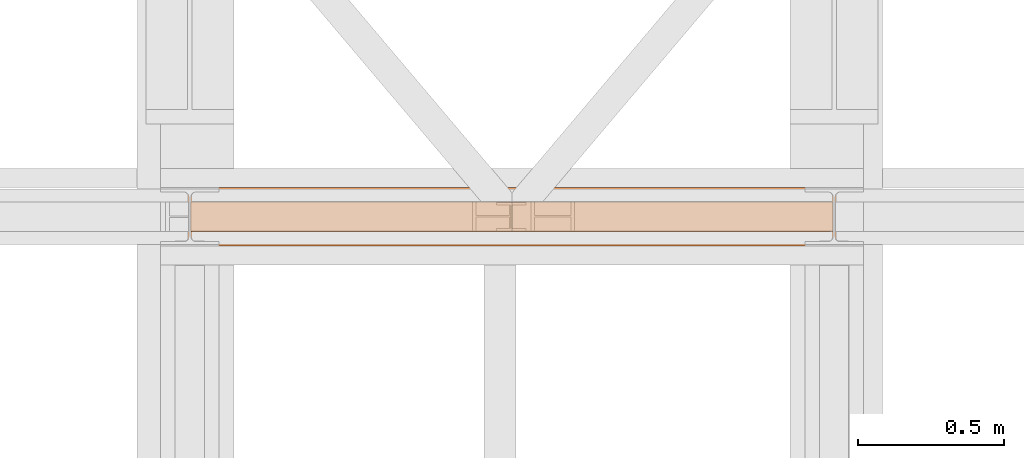
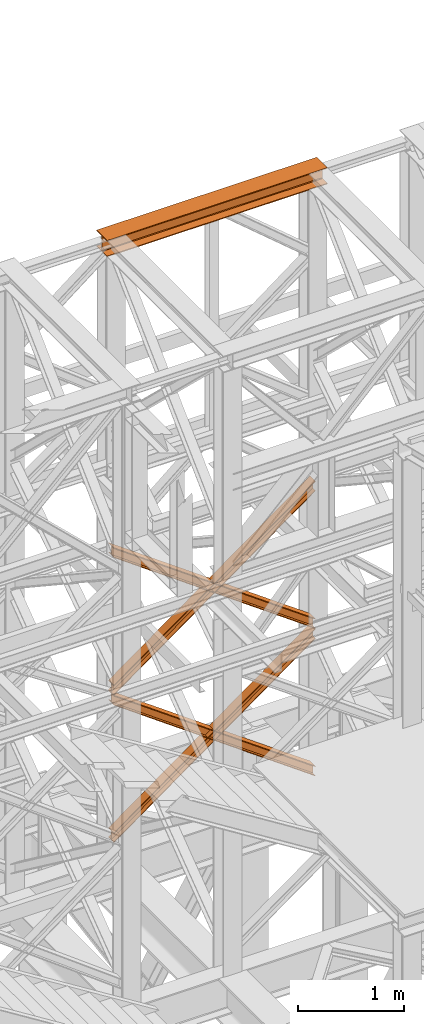
# One storey, part 119 of 208: 5 proxies.
"""IFC2X3 building model written with IfcOpenShell, lengths in millimetres."""

from ifc_helpers import new_model, entity, si_unit, converted_unit, frame, origin, origin_with_axes, place, context, subcontext, project, spatial, faceted_brep, element, save


model = new_model("IFC2X3")

# Units and contexts
model_context = context("Model", 3, precision=1e-05, world=origin())
plan_context = context("Plan", 3, precision=1e-05, world=origin())
body_context = subcontext(model_context, "Body", "Model", "MODEL_VIEW")
ifc_project = project(units=[si_unit("LENGTHUNIT", "METRE", prefix="MILLI"), converted_unit("PLANEANGLEUNIT", "DEGREE", entity("IfcPlaneAngleMeasure", 0.0174532925199433), si_unit("PLANEANGLEUNIT", "RADIAN"), dimensions=[0, 0, 0, 0, 0, 0, 0]), si_unit("AREAUNIT", "SQUARE_METRE"), si_unit("VOLUMEUNIT", "CUBIC_METRE")], contexts=[model_context, plan_context])

# Building, storey
building_placement = place(None, origin())
building = spatial("IfcBuilding", under=ifc_project, at=building_placement, CompositionType="COMPLEX")
storey_placement = place(building_placement, origin_with_axes())
storey = spatial("IfcBuildingStorey", under=building, at=storey_placement, Name="Geschoss", CompositionType="ELEMENT")

# Proxies
proxy_1_placement = place(storey_placement, frame((-106.745032961451, -13862.574391808, 12249.99005869381), z_axis=(0.0, 0.0, 1.0), x_axis=(1.0, 0.0, 0.0)))
element("IfcBuildingElementProxy", 1, at=proxy_1_placement, inside=storey, context=body_context, shape_type="Brep", body=[
    faceted_brep([(0.009999999999990905, 0.01000000000021828, 0.01000000000021828), (0.009999999999990905, 200.0100029802325, 0.01000000000021828), (0.009999999999990905, 200.0100029802325, 10.00999791383765), (0.009999999999990905, 121.2600035762789, 10.01000536441825), (0.009999999999990905, 111.9441915473344, 11.87455041170142), (0.009999999999990905, 105.1245498640838, 18.69419349193595), (0.009999999999990905, 103.2600015571716, 28.01000458955787), (0.009999999999990905, 103.2600015571716, 162.0100153779986), (0.009999999999990905, 105.1245498640838, 171.3258264756205), (0.009999999999990905, 111.9441915473344, 178.145469555855), (0.009999999999990905, 121.2600035762789, 180.0100146031382), (0.009999999999990905, 200.0100029802325, 180.0100146031382), (0.009999999999990905, 200.0100029802325, 190.0100125169756), (0.009999999999990905, 0.01000000000021828, 190.0100125169756), (0.009999999999990905, 0.01000000000021828, 180.0100146031382), (0.009999999999990905, 78.75999940395377, 180.0100146031382), (0.009999999999990905, 88.07581143289826, 178.145469555855), (0.009999999999990905, 94.89545311614893, 171.3258264756205), (0.009999999999990905, 96.76000142306111, 162.0100153779986), (0.009999999999990905, 96.76000142306111, 28.01000458955787), (0.009999999999990905, 94.89545311614893, 18.69419349193595), (0.009999999999990905, 88.07581143289826, 11.87455041170142), (0.009999999999990905, 78.75999940395377, 10.01000536441825), (0.009999999999990905, 0.01000000000021828, 10.00999791383765), (0.009999999999990905, 200.0100029802325, 0.01000000000021828), (0.009999999999990905, 0.01000000000021828, 0.01000000000021828), (2400.010002980233, 0.01000000000021828, 0.01000000000021828), (2400.010002980233, 200.0100029802325, 0.01000000000021828), (0.009999999999990905, 200.0100029802325, 10.00999791383765), (0.009999999999990905, 200.0100029802325, 0.01000000000021828), (2400.010002980233, 200.0100029802325, 0.01000000000021828), (2400.010002980233, 200.0100029802325, 10.00999791383765), (0.009999999999990905, 121.2600035762789, 10.01000536441825), (0.009999999999990905, 200.0100029802325, 10.00999791383765), (2400.010002980233, 200.0100029802325, 10.00999791383765), (2400.010002980233, 121.2600035762789, 10.01000536441825), (0.009999999999990905, 111.9441915473344, 11.87455041170142), (0.009999999999990905, 121.2600035762789, 10.01000536441825), (2400.010002980233, 121.2600035762789, 10.01000536441825), (2400.010002980233, 111.9441915473344, 11.87455041170142), (0.009999999999990905, 105.1245498640838, 18.69419349193595), (0.009999999999990905, 111.9441915473344, 11.87455041170142), (2400.010002980233, 111.9441915473344, 11.87455041170142), (2400.010002980233, 105.1245498640838, 18.69419349193595), (0.009999999999990905, 103.2600015571716, 28.01000458955787), (0.009999999999990905, 105.1245498640838, 18.69419349193595), (2400.010002980233, 105.1245498640838, 18.69419349193595), (2400.010002980233, 103.2600015571716, 28.01000458955787), (0.009999999999990905, 103.2600015571716, 162.0100153779986), (0.009999999999990905, 103.2600015571716, 28.01000458955787), (2400.010002980233, 103.2600015571716, 28.01000458955787), (2400.010002980233, 103.2600015571716, 162.0100153779986), (0.009999999999990905, 105.1245498640838, 171.3258264756205), (0.009999999999990905, 103.2600015571716, 162.0100153779986), (2400.010002980233, 103.2600015571716, 162.0100153779986), (2400.010002980233, 105.1245498640838, 171.3258264756205), (0.009999999999990905, 111.9441915473344, 178.145469555855), (0.009999999999990905, 105.1245498640838, 171.3258264756205), (2400.010002980233, 105.1245498640838, 171.3258264756205), (2400.010002980233, 111.9441915473344, 178.145469555855), (0.009999999999990905, 121.2600035762789, 180.0100146031382), (0.009999999999990905, 111.9441915473344, 178.145469555855), (2400.010002980233, 111.9441915473344, 178.145469555855), (2400.010002980233, 121.2600035762789, 180.0100146031382), (0.009999999999990905, 200.0100029802325, 180.0100146031382), (0.009999999999990905, 121.2600035762789, 180.0100146031382), (2400.010002980233, 121.2600035762789, 180.0100146031382), (2400.010002980233, 200.0100029802325, 180.0100146031382), (0.009999999999990905, 200.0100029802325, 190.0100125169756), (0.009999999999990905, 200.0100029802325, 180.0100146031382), (2400.010002980233, 200.0100029802325, 180.0100146031382), (2400.010002980233, 200.0100029802325, 190.0100125169756), (0.009999999999990905, 0.01000000000021828, 190.0100125169756), (0.009999999999990905, 200.0100029802325, 190.0100125169756), (2400.010002980233, 200.0100029802325, 190.0100125169756), (2400.010002980233, 0.01000000000021828, 190.0100125169756), (0.009999999999990905, 0.01000000000021828, 180.0100146031382), (0.009999999999990905, 0.01000000000021828, 190.0100125169756), (2400.010002980233, 0.01000000000021828, 190.0100125169756), (2400.010002980233, 0.01000000000021828, 180.0100146031382), (0.009999999999990905, 78.75999940395377, 180.0100146031382), (0.009999999999990905, 0.01000000000021828, 180.0100146031382), (2400.010002980233, 0.01000000000021828, 180.0100146031382), (2400.010002980233, 78.75999940395377, 180.0100146031382), (0.009999999999990905, 88.07581143289826, 178.145469555855), (0.009999999999990905, 78.75999940395377, 180.0100146031382), (2400.010002980233, 78.75999940395377, 180.0100146031382), (2400.010002980233, 88.07581143289826, 178.145469555855), (0.009999999999990905, 94.89545311614893, 171.3258264756205), (0.009999999999990905, 88.07581143289826, 178.145469555855), (2400.010002980233, 88.07581143289826, 178.145469555855), (2400.010002980233, 94.89545311614893, 171.3258264756205), (0.009999999999990905, 96.76000142306111, 162.0100153779986), (0.009999999999990905, 94.89545311614893, 171.3258264756205), (2400.010002980233, 94.89545311614893, 171.3258264756205), (2400.010002980233, 96.76000142306111, 162.0100153779986), (0.009999999999990905, 96.76000142306111, 28.01000458955787), (0.009999999999990905, 96.76000142306111, 162.0100153779986), (2400.010002980233, 96.76000142306111, 162.0100153779986), (2400.010002980233, 96.76000142306111, 28.01000458955787), (0.009999999999990905, 94.89545311614893, 18.69419349193595), (0.009999999999990905, 96.76000142306111, 28.01000458955787), (2400.010002980233, 96.76000142306111, 28.01000458955787), (2400.010002980233, 94.89545311614893, 18.69419349193595), (0.009999999999990905, 88.07581143289826, 11.87455041170142), (0.009999999999990905, 94.89545311614893, 18.69419349193595), (2400.010002980233, 94.89545311614893, 18.69419349193595), (2400.010002980233, 88.07581143289826, 11.87455041170142), (0.009999999999990905, 78.75999940395377, 10.01000536441825), (0.009999999999990905, 88.07581143289826, 11.87455041170142), (2400.010002980233, 88.07581143289826, 11.87455041170142), (2400.010002980233, 78.75999940395377, 10.01000536441825), (0.009999999999990905, 0.01000000000021828, 10.00999791383765), (0.009999999999990905, 78.75999940395377, 10.01000536441825), (2400.010002980233, 78.75999940395377, 10.01000536441825), (2400.010002980233, 0.01000000000021828, 10.00999791383765), (0.009999999999990905, 0.01000000000021828, 0.01000000000021828), (0.009999999999990905, 0.01000000000021828, 10.00999791383765), (2400.010002980233, 0.01000000000021828, 10.00999791383765), (2400.010002980233, 0.01000000000021828, 0.01000000000021828), (2400.010002980233, 0.01000000000021828, 0.01000000000021828), (2400.010002980233, 0.01000000000021828, 10.00999791383765), (2400.010002980233, 78.75999940395377, 10.01000536441825), (2400.010002980233, 88.07581143289826, 11.87455041170142), (2400.010002980233, 94.89545311614893, 18.69419349193595), (2400.010002980233, 96.76000142306111, 28.01000458955787), (2400.010002980233, 96.76000142306111, 162.0100153779986), (2400.010002980233, 94.89545311614893, 171.3258264756205), (2400.010002980233, 88.07581143289826, 178.145469555855), (2400.010002980233, 78.75999940395377, 180.0100146031382), (2400.010002980233, 0.01000000000021828, 180.0100146031382), (2400.010002980233, 0.01000000000021828, 190.0100125169756), (2400.010002980233, 200.0100029802325, 190.0100125169756), (2400.010002980233, 200.0100029802325, 180.0100146031382), (2400.010002980233, 121.2600035762789, 180.0100146031382), (2400.010002980233, 111.9441915473344, 178.145469555855), (2400.010002980233, 105.1245498640838, 171.3258264756205), (2400.010002980233, 103.2600015571716, 162.0100153779986), (2400.010002980233, 103.2600015571716, 28.01000458955787), (2400.010002980233, 105.1245498640838, 18.69419349193595), (2400.010002980233, 111.9441915473344, 11.87455041170142), (2400.010002980233, 121.2600035762789, 10.01000536441825), (2400.010002980233, 200.0100029802325, 10.00999791383765), (2400.010002980233, 200.0100029802325, 0.01000000000021828)], [[[0, 1, 2, 3, 4, 5, 6, 7, 8, 9, 10, 11, 12, 13, 14, 15, 16, 17, 18, 19, 20, 21, 22, 23]], [[24, 25, 26, 27]], [[28, 29, 30, 31]], [[32, 33, 34, 35]], [[36, 37, 38, 39]], [[40, 41, 42, 43]], [[44, 45, 46, 47]], [[48, 49, 50, 51]], [[52, 53, 54, 55]], [[56, 57, 58, 59]], [[60, 61, 62, 63]], [[64, 65, 66, 67]], [[68, 69, 70, 71]], [[72, 73, 74, 75]], [[76, 77, 78, 79]], [[80, 81, 82, 83]], [[84, 85, 86, 87]], [[88, 89, 90, 91]], [[92, 93, 94, 95]], [[96, 97, 98, 99]], [[100, 101, 102, 103]], [[104, 105, 106, 107]], [[108, 109, 110, 111]], [[112, 113, 114, 115]], [[116, 117, 118, 119]], [[120, 121, 122, 123, 124, 125, 126, 127, 128, 129, 130, 131, 132, 133, 134, 135, 136, 137, 138, 139, 140, 141, 142, 143]]], orient=[[False], [False], [False], [False], [False], [False], [False], [False], [False], [False], [False], [False], [False], [False], [False], [False], [False], [False], [False], [False], [False], [False], [False], [False], [False], [False]]),
])
proxy_2_placement = place(storey_placement, frame((-4.245031471322136, -13812.57439031789, 5434.990005364416), z_axis=(0.0, 0.0, 1.0), x_axis=(1.0, 0.0, 0.0)))
element("IfcBuildingElementProxy", 2, at=proxy_2_placement, inside=storey, context=body_context, shape_type="Brep", body=[
    faceted_brep([(2194.25999993293, 0.01000000000021828, 1583.81921929576), (0.009999999999990905, 0.01000000000021828, 0.01000000000112777), (0.009999999999990905, 0.01000000000021828, 9.69256505868816), (2194.25999993293, 0.01000000000021828, 1593.501784354445), (2194.25999993293, 100.0100000000002, 1583.819219295759), (0.009999999999990905, 100.0100000000002, 0.01000000000021828), (0.009999999999990905, 0.01000000000021828, 0.01000000000112777), (2194.25999993293, 0.01000000000021828, 1583.81921929576), (2194.25999993293, 100.0100000000002, 1593.501784354445), (0.009999999999990905, 100.0100000000002, 9.69256505868816), (0.009999999999990905, 100.0100000000002, 0.01000000000021828), (2194.25999993293, 100.0100000000002, 1583.819219295759), (2194.25999993293, 52.51000000000022, 1593.501784354445), (0.009999999999990905, 52.51000000000022, 9.69256505868816), (0.009999999999990905, 100.0100000000002, 9.69256505868816), (2194.25999993293, 100.0100000000002, 1593.501784354445), (2194.259999932929, 52.51000000000022, 1690.327434941312), (0.009999999999990905, 52.51000000000022, 106.5182156455558), (0.009999999999990905, 52.51000000000022, 9.69256505868816), (2194.25999993293, 52.51000000000022, 1593.501784354445), (2194.25999993293, 100.0100000000002, 1690.327434941312), (0.01000000000180989, 100.0100000000002, 106.5182156455558), (0.009999999999990905, 52.51000000000022, 106.5182156455558), (2194.259999932929, 52.51000000000022, 1690.327434941312), (2194.25999993293, 100.0100000000002, 1700.01), (0.009999999999990905, 100.0100000000002, 116.2007807042428), (0.01000000000180989, 100.0100000000002, 106.5182156455558), (2194.25999993293, 100.0100000000002, 1690.327434941312), (2194.259999932929, 0.01000000000021828, 1700.01), (0.009999999999990905, 0.01000000000021828, 116.2007807042428), (0.009999999999990905, 100.0100000000002, 116.2007807042428), (2194.25999993293, 100.0100000000002, 1700.01), (2194.25999993293, 0.01000000000021828, 1690.327434941312), (0.009999999999990905, 0.01000000000021828, 106.5182156455549), (0.009999999999990905, 0.01000000000021828, 116.2007807042428), (2194.259999932929, 0.01000000000021828, 1700.01), (2194.25999993293, 47.51000000000022, 1690.327434941311), (0.009999999999990905, 47.51000000000022, 106.5182156455549), (0.009999999999990905, 0.01000000000021828, 106.5182156455549), (2194.25999993293, 0.01000000000021828, 1690.327434941312), (2194.25999993293, 47.51000000000022, 1593.501784354445), (0.009999999999990905, 47.51000000000022, 9.69256505868816), (0.009999999999990905, 47.51000000000022, 106.5182156455549), (2194.25999993293, 47.51000000000022, 1690.327434941311), (2194.25999993293, 0.01000000000021828, 1593.501784354445), (0.009999999999990905, 0.01000000000021828, 9.69256505868816), (0.009999999999990905, 47.51000000000022, 9.69256505868816), (2194.25999993293, 47.51000000000022, 1593.501784354445), (2194.25999993293, 0.01000000000021828, 1593.501784354445), (2194.25999993293, 47.51000000000022, 1593.501784354445), (2194.25999993293, 47.51000000000022, 1690.327434941311), (2194.25999993293, 0.01000000000021828, 1690.327434941312), (2194.259999932929, 0.01000000000021828, 1700.01), (2194.25999993293, 100.0100000000002, 1700.01), (2194.25999993293, 100.0100000000002, 1690.327434941312), (2194.259999932929, 52.51000000000022, 1690.327434941312), (2194.25999993293, 52.51000000000022, 1593.501784354445), (2194.25999993293, 100.0100000000002, 1593.501784354445), (2194.25999993293, 100.0100000000002, 1583.819219295759), (2194.25999993293, 0.01000000000021828, 1583.81921929576), (0.009999999999990905, 0.01000000000021828, 0.01000000000112777), (0.009999999999990905, 100.0100000000002, 0.01000000000021828), (0.009999999999990905, 100.0100000000002, 9.69256505868816), (0.009999999999990905, 52.51000000000022, 9.69256505868816), (0.009999999999990905, 52.51000000000022, 106.5182156455558), (0.01000000000180989, 100.0100000000002, 106.5182156455558), (0.009999999999990905, 100.0100000000002, 116.2007807042428), (0.009999999999990905, 0.01000000000021828, 116.2007807042428), (0.009999999999990905, 0.01000000000021828, 106.5182156455549), (0.009999999999990905, 47.51000000000022, 106.5182156455549), (0.009999999999990905, 47.51000000000022, 9.69256505868816), (0.009999999999990905, 0.01000000000021828, 9.69256505868816)], [[[0, 1, 2, 3]], [[4, 5, 6, 7]], [[8, 9, 10, 11]], [[12, 13, 14, 15]], [[16, 17, 18, 19]], [[20, 21, 22, 23]], [[24, 25, 26, 27]], [[28, 29, 30, 31]], [[32, 33, 34, 35]], [[36, 37, 38, 39]], [[40, 41, 42, 43]], [[44, 45, 46, 47]], [[48, 49, 50, 51, 52, 53, 54, 55, 56, 57, 58, 59]], [[60, 61, 62, 63, 64, 65, 66, 67, 68, 69, 70, 71]]], orient=[[False], [False], [False], [False], [False], [False], [False], [False], [False], [False], [False], [False], [False], [False]]),
])
proxy_3_placement = place(storey_placement, frame((-4.245031471322136, -13812.57439031789, 5434.990005364416), z_axis=(0.0, 0.0, 1.0), x_axis=(1.0, 0.0, 0.0)))
element("IfcBuildingElementProxy", 3, at=proxy_3_placement, inside=storey, context=body_context, shape_type="Brep", body=[
    faceted_brep([(0.009999999999990905, 0.01000000000021828, 1593.501784354445), (2194.25999993293, 0.01000000000021828, 9.692565058686341), (2194.25999993293, 0.01000000000021828, 0.01000000000112777), (0.009999999999990905, 0.01000000000021828, 1583.819219295759), (0.009999999999990905, 0.01000000000021828, 1583.819219295759), (2194.25999993293, 0.01000000000021828, 0.01000000000112777), (2194.25999993293, 100.0100000000002, 0.01000000000021828), (0.009999999999990905, 100.0100000000002, 1583.819219295759), (0.009999999999990905, 100.0100000000002, 1583.819219295759), (2194.25999993293, 100.0100000000002, 0.01000000000021828), (2194.25999993293, 100.0100000000002, 9.692565058686341), (0.009999999999990905, 100.0100000000002, 1593.501784354445), (0.009999999999990905, 100.0100000000002, 1593.501784354445), (2194.25999993293, 100.0100000000002, 9.692565058686341), (2194.25999993293, 52.51000000000022, 9.692565058686341), (0.009999999999990905, 52.51000000000022, 1593.501784354445), (0.009999999999990905, 52.51000000000022, 1593.501784354445), (2194.25999993293, 52.51000000000022, 9.692565058686341), (2194.259999932929, 52.51000000000022, 106.5182156455549), (0.009999999999990905, 52.51000000000022, 1690.327434941313), (0.009999999999990905, 52.51000000000022, 1690.327434941313), (2194.259999932929, 52.51000000000022, 106.5182156455549), (2194.25999993293, 100.0100000000002, 106.5182156455549), (0.009999999999990905, 100.0100000000002, 1690.327434941311), (0.009999999999990905, 100.0100000000002, 1690.327434941311), (2194.25999993293, 100.0100000000002, 106.5182156455549), (2194.259999932929, 100.0100000000002, 116.2007807042419), (0.009999999999990905, 100.0100000000002, 1700.01), (0.009999999999990905, 100.0100000000002, 1700.01), (2194.259999932929, 100.0100000000002, 116.2007807042419), (2194.25999993293, 0.01000000000021828, 116.2007807042419), (0.009999999999990905, 0.01000000000021828, 1700.01), (0.009999999999990905, 0.01000000000021828, 1700.01), (2194.25999993293, 0.01000000000021828, 116.2007807042419), (2194.25999993293, 0.01000000000021828, 106.5182156455549), (0.009999999999990905, 0.01000000000021828, 1690.327434941313), (0.009999999999990905, 0.01000000000021828, 1690.327434941313), (2194.25999993293, 0.01000000000021828, 106.5182156455549), (2194.25999993293, 47.51000000000022, 106.5182156455539), (0.009999999999990905, 47.51000000000022, 1690.327434941311), (0.009999999999990905, 47.51000000000022, 1690.327434941311), (2194.25999993293, 47.51000000000022, 106.5182156455539), (2194.25999993293, 47.51000000000022, 9.692565058686341), (0.009999999999990905, 47.51000000000022, 1593.501784354445), (0.009999999999990905, 47.51000000000022, 1593.501784354445), (2194.25999993293, 47.51000000000022, 9.692565058686341), (2194.25999993293, 0.01000000000021828, 9.692565058686341), (0.009999999999990905, 0.01000000000021828, 1593.501784354445), (2194.25999993293, 0.01000000000021828, 9.692565058686341), (2194.25999993293, 47.51000000000022, 9.692565058686341), (2194.25999993293, 47.51000000000022, 106.5182156455539), (2194.25999993293, 0.01000000000021828, 106.5182156455549), (2194.25999993293, 0.01000000000021828, 116.2007807042419), (2194.259999932929, 100.0100000000002, 116.2007807042419), (2194.25999993293, 100.0100000000002, 106.5182156455549), (2194.259999932929, 52.51000000000022, 106.5182156455549), (2194.25999993293, 52.51000000000022, 9.692565058686341), (2194.25999993293, 100.0100000000002, 9.692565058686341), (2194.25999993293, 100.0100000000002, 0.01000000000021828), (2194.25999993293, 0.01000000000021828, 0.01000000000112777), (0.009999999999990905, 0.01000000000021828, 1583.819219295759), (0.009999999999990905, 100.0100000000002, 1583.819219295759), (0.009999999999990905, 100.0100000000002, 1593.501784354445), (0.009999999999990905, 52.51000000000022, 1593.501784354445), (0.009999999999990905, 52.51000000000022, 1690.327434941313), (0.009999999999990905, 100.0100000000002, 1690.327434941311), (0.009999999999990905, 100.0100000000002, 1700.01), (0.009999999999990905, 0.01000000000021828, 1700.01), (0.009999999999990905, 0.01000000000021828, 1690.327434941313), (0.009999999999990905, 47.51000000000022, 1690.327434941311), (0.009999999999990905, 47.51000000000022, 1593.501784354445), (0.009999999999990905, 0.01000000000021828, 1593.501784354445)], [[[0, 1, 2, 3]], [[4, 5, 6, 7]], [[8, 9, 10, 11]], [[12, 13, 14, 15]], [[16, 17, 18, 19]], [[20, 21, 22, 23]], [[24, 25, 26, 27]], [[28, 29, 30, 31]], [[32, 33, 34, 35]], [[36, 37, 38, 39]], [[40, 41, 42, 43]], [[44, 45, 46, 47]], [[48, 49, 50, 51, 52, 53, 54, 55, 56, 57, 58, 59]], [[60, 61, 62, 63, 64, 65, 66, 67, 68, 69, 70, 71]]], orient=[[False], [False], [False], [False], [False], [False], [False], [False], [False], [False], [False], [False], [False], [False]]),
])
proxy_4_placement = place(storey_placement, frame((-4.245031471322136, -13812.57439031789, 7134.990005364416), z_axis=(0.0, 0.0, 1.0), x_axis=(1.0, 0.0, 0.0)))
element("IfcBuildingElementProxy", 4, at=proxy_4_placement, inside=storey, context=body_context, shape_type="Brep", body=[
    faceted_brep([(2194.25999993293, 0.01000000000021828, 1583.81921929576), (0.009999999999990905, 0.01000000000021828, 0.01000000000112777), (0.009999999999990905, 0.01000000000021828, 9.69256505868816), (2194.25999993293, 0.01000000000021828, 1593.501784354445), (2194.25999993293, 100.0100000000002, 1583.819219295758), (0.009999999999990905, 100.0100000000002, 0.01000000000021828), (0.009999999999990905, 0.01000000000021828, 0.01000000000112777), (2194.25999993293, 0.01000000000021828, 1583.81921929576), (2194.25999993293, 100.0100000000002, 1593.501784354445), (0.009999999999990905, 100.0100000000002, 9.69256505868816), (0.009999999999990905, 100.0100000000002, 0.01000000000021828), (2194.25999993293, 100.0100000000002, 1583.819219295758), (2194.25999993293, 52.51000000000022, 1593.501784354445), (0.009999999999990905, 52.51000000000022, 9.69256505868816), (0.009999999999990905, 100.0100000000002, 9.69256505868816), (2194.25999993293, 100.0100000000002, 1593.501784354445), (2194.259999932929, 52.51000000000022, 1690.327434941311), (0.009999999999990905, 52.51000000000022, 106.5182156455558), (0.009999999999990905, 52.51000000000022, 9.69256505868816), (2194.25999993293, 52.51000000000022, 1593.501784354445), (2194.25999993293, 100.0100000000002, 1690.327434941311), (0.01000000000180989, 100.0100000000002, 106.5182156455558), (0.009999999999990905, 52.51000000000022, 106.5182156455558), (2194.259999932929, 52.51000000000022, 1690.327434941311), (2194.25999993293, 100.0100000000002, 1700.01), (0.009999999999990905, 100.0100000000002, 116.2007807042428), (0.01000000000180989, 100.0100000000002, 106.5182156455558), (2194.25999993293, 100.0100000000002, 1690.327434941311), (2194.259999932929, 0.01000000000021828, 1700.01), (0.009999999999990905, 0.01000000000021828, 116.2007807042428), (0.009999999999990905, 100.0100000000002, 116.2007807042428), (2194.25999993293, 100.0100000000002, 1700.01), (2194.25999993293, 0.01000000000021828, 1690.327434941311), (0.009999999999990905, 0.01000000000021828, 106.5182156455549), (0.009999999999990905, 0.01000000000021828, 116.2007807042428), (2194.259999932929, 0.01000000000021828, 1700.01), (2194.25999993293, 47.51000000000022, 1690.327434941311), (0.009999999999990905, 47.51000000000022, 106.5182156455549), (0.009999999999990905, 0.01000000000021828, 106.5182156455549), (2194.25999993293, 0.01000000000021828, 1690.327434941311), (2194.25999993293, 47.51000000000022, 1593.501784354445), (0.009999999999990905, 47.51000000000022, 9.69256505868816), (0.009999999999990905, 47.51000000000022, 106.5182156455549), (2194.25999993293, 47.51000000000022, 1690.327434941311), (2194.25999993293, 0.01000000000021828, 1593.501784354445), (0.009999999999990905, 0.01000000000021828, 9.69256505868816), (0.009999999999990905, 47.51000000000022, 9.69256505868816), (2194.25999993293, 47.51000000000022, 1593.501784354445), (2194.25999993293, 0.01000000000021828, 1593.501784354445), (2194.25999993293, 47.51000000000022, 1593.501784354445), (2194.25999993293, 47.51000000000022, 1690.327434941311), (2194.25999993293, 0.01000000000021828, 1690.327434941311), (2194.259999932929, 0.01000000000021828, 1700.01), (2194.25999993293, 100.0100000000002, 1700.01), (2194.25999993293, 100.0100000000002, 1690.327434941311), (2194.259999932929, 52.51000000000022, 1690.327434941311), (2194.25999993293, 52.51000000000022, 1593.501784354445), (2194.25999993293, 100.0100000000002, 1593.501784354445), (2194.25999993293, 100.0100000000002, 1583.819219295758), (2194.25999993293, 0.01000000000021828, 1583.81921929576), (0.009999999999990905, 0.01000000000021828, 0.01000000000112777), (0.009999999999990905, 100.0100000000002, 0.01000000000021828), (0.009999999999990905, 100.0100000000002, 9.69256505868816), (0.009999999999990905, 52.51000000000022, 9.69256505868816), (0.009999999999990905, 52.51000000000022, 106.5182156455558), (0.01000000000180989, 100.0100000000002, 106.5182156455558), (0.009999999999990905, 100.0100000000002, 116.2007807042428), (0.009999999999990905, 0.01000000000021828, 116.2007807042428), (0.009999999999990905, 0.01000000000021828, 106.5182156455549), (0.009999999999990905, 47.51000000000022, 106.5182156455549), (0.009999999999990905, 47.51000000000022, 9.69256505868816), (0.009999999999990905, 0.01000000000021828, 9.69256505868816)], [[[0, 1, 2, 3]], [[4, 5, 6, 7]], [[8, 9, 10, 11]], [[12, 13, 14, 15]], [[16, 17, 18, 19]], [[20, 21, 22, 23]], [[24, 25, 26, 27]], [[28, 29, 30, 31]], [[32, 33, 34, 35]], [[36, 37, 38, 39]], [[40, 41, 42, 43]], [[44, 45, 46, 47]], [[48, 49, 50, 51, 52, 53, 54, 55, 56, 57, 58, 59]], [[60, 61, 62, 63, 64, 65, 66, 67, 68, 69, 70, 71]]], orient=[[False], [False], [False], [False], [False], [False], [False], [False], [False], [False], [False], [False], [False], [False]]),
])
proxy_5_placement = place(storey_placement, frame((-4.245031471322136, -13812.57439031789, 7134.990005364416), z_axis=(0.0, 0.0, 1.0), x_axis=(1.0, 0.0, 0.0)))
element("IfcBuildingElementProxy", 5, at=proxy_5_placement, inside=storey, context=body_context, shape_type="Brep", body=[
    faceted_brep([(0.009999999999990905, 0.01000000000021828, 1593.501784354445), (2194.25999993293, 0.01000000000021828, 9.692565058686341), (2194.25999993293, 0.01000000000021828, 0.01000000000112777), (0.009999999999990905, 0.01000000000021828, 1583.819219295758), (0.009999999999990905, 0.01000000000021828, 1583.819219295758), (2194.25999993293, 0.01000000000021828, 0.01000000000112777), (2194.25999993293, 100.0100000000002, 0.01000000000021828), (0.009999999999990905, 100.0100000000002, 1583.819219295758), (0.009999999999990905, 100.0100000000002, 1583.819219295758), (2194.25999993293, 100.0100000000002, 0.01000000000021828), (2194.25999993293, 100.0100000000002, 9.692565058686341), (0.009999999999990905, 100.0100000000002, 1593.501784354445), (0.009999999999990905, 100.0100000000002, 1593.501784354445), (2194.25999993293, 100.0100000000002, 9.692565058686341), (2194.25999993293, 52.51000000000022, 9.692565058686341), (0.009999999999990905, 52.51000000000022, 1593.501784354445), (0.009999999999990905, 52.51000000000022, 1593.501784354445), (2194.25999993293, 52.51000000000022, 9.692565058686341), (2194.259999932929, 52.51000000000022, 106.5182156455549), (0.009999999999990905, 52.51000000000022, 1690.327434941313), (0.009999999999990905, 52.51000000000022, 1690.327434941313), (2194.259999932929, 52.51000000000022, 106.5182156455549), (2194.25999993293, 100.0100000000002, 106.5182156455549), (0.009999999999990905, 100.0100000000002, 1690.327434941311), (0.009999999999990905, 100.0100000000002, 1690.327434941311), (2194.25999993293, 100.0100000000002, 106.5182156455549), (2194.259999932929, 100.0100000000002, 116.2007807042419), (0.009999999999990905, 100.0100000000002, 1700.01), (0.009999999999990905, 100.0100000000002, 1700.01), (2194.259999932929, 100.0100000000002, 116.2007807042419), (2194.25999993293, 0.01000000000021828, 116.2007807042419), (0.009999999999990905, 0.01000000000021828, 1700.01), (0.009999999999990905, 0.01000000000021828, 1700.01), (2194.25999993293, 0.01000000000021828, 116.2007807042419), (2194.25999993293, 0.01000000000021828, 106.5182156455549), (0.009999999999990905, 0.01000000000021828, 1690.327434941313), (0.009999999999990905, 0.01000000000021828, 1690.327434941313), (2194.25999993293, 0.01000000000021828, 106.5182156455549), (2194.25999993293, 47.51000000000022, 106.5182156455539), (0.009999999999990905, 47.51000000000022, 1690.327434941311), (0.009999999999990905, 47.51000000000022, 1690.327434941311), (2194.25999993293, 47.51000000000022, 106.5182156455539), (2194.25999993293, 47.51000000000022, 9.692565058686341), (0.009999999999990905, 47.51000000000022, 1593.501784354445), (0.009999999999990905, 47.51000000000022, 1593.501784354445), (2194.25999993293, 47.51000000000022, 9.692565058686341), (2194.25999993293, 0.01000000000021828, 9.692565058686341), (0.009999999999990905, 0.01000000000021828, 1593.501784354445), (2194.25999993293, 0.01000000000021828, 9.692565058686341), (2194.25999993293, 47.51000000000022, 9.692565058686341), (2194.25999993293, 47.51000000000022, 106.5182156455539), (2194.25999993293, 0.01000000000021828, 106.5182156455549), (2194.25999993293, 0.01000000000021828, 116.2007807042419), (2194.259999932929, 100.0100000000002, 116.2007807042419), (2194.25999993293, 100.0100000000002, 106.5182156455549), (2194.259999932929, 52.51000000000022, 106.5182156455549), (2194.25999993293, 52.51000000000022, 9.692565058686341), (2194.25999993293, 100.0100000000002, 9.692565058686341), (2194.25999993293, 100.0100000000002, 0.01000000000021828), (2194.25999993293, 0.01000000000021828, 0.01000000000112777), (0.009999999999990905, 0.01000000000021828, 1583.819219295758), (0.009999999999990905, 100.0100000000002, 1583.819219295758), (0.009999999999990905, 100.0100000000002, 1593.501784354445), (0.009999999999990905, 52.51000000000022, 1593.501784354445), (0.009999999999990905, 52.51000000000022, 1690.327434941313), (0.009999999999990905, 100.0100000000002, 1690.327434941311), (0.009999999999990905, 100.0100000000002, 1700.01), (0.009999999999990905, 0.01000000000021828, 1700.01), (0.009999999999990905, 0.01000000000021828, 1690.327434941313), (0.009999999999990905, 47.51000000000022, 1690.327434941311), (0.009999999999990905, 47.51000000000022, 1593.501784354445), (0.009999999999990905, 0.01000000000021828, 1593.501784354445)], [[[0, 1, 2, 3]], [[4, 5, 6, 7]], [[8, 9, 10, 11]], [[12, 13, 14, 15]], [[16, 17, 18, 19]], [[20, 21, 22, 23]], [[24, 25, 26, 27]], [[28, 29, 30, 31]], [[32, 33, 34, 35]], [[36, 37, 38, 39]], [[40, 41, 42, 43]], [[44, 45, 46, 47]], [[48, 49, 50, 51, 52, 53, 54, 55, 56, 57, 58, 59]], [[60, 61, 62, 63, 64, 65, 66, 67, 68, 69, 70, 71]]], orient=[[False], [False], [False], [False], [False], [False], [False], [False], [False], [False], [False], [False], [False], [False]]),
])

save(model, "model.ifc")
